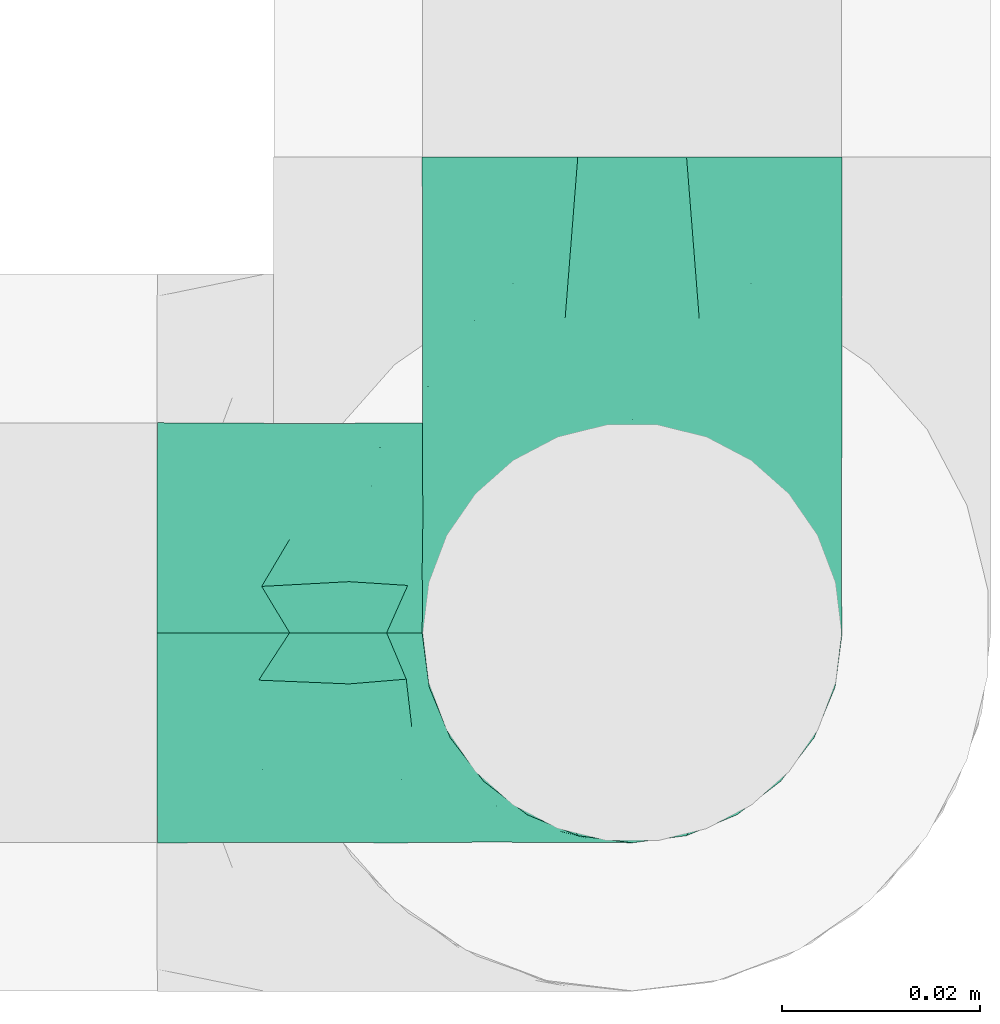
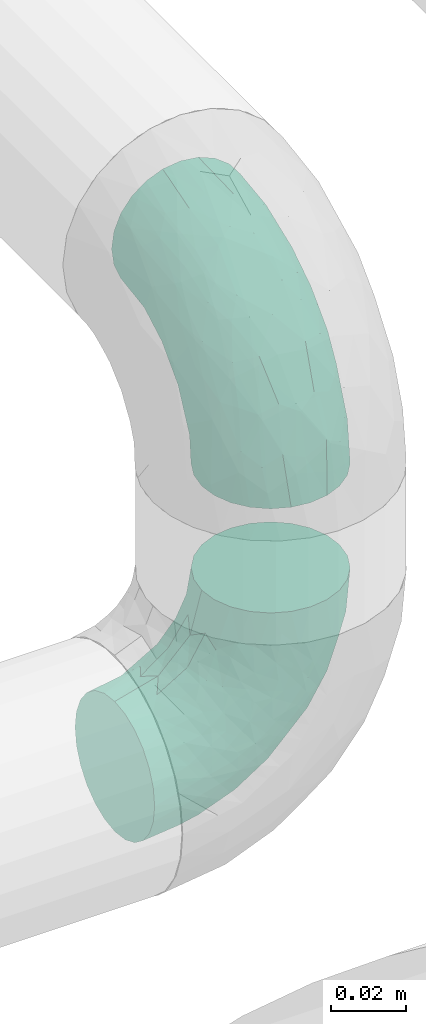
# One storey, part 35 of 39: 2 flow fittings.
"""IFC2X3 building model written with IfcOpenShell, lengths in millimetres."""

import ifcopenshell
import ifcopenshell.guid

model = None  # the IFC model being written
_history = None  # IfcOwnerHistory: only IFC2X3 demands one
_inside = {}  # id of a spatial element -> (the spatial element, [elements in it])
_under = {}  # id of a project, library or spatial element -> (it, [spatial elements below it])
_declared = {}  # id of a project -> (the project, [libraries it declares])
_typed = {}  # id of a type object -> (the type object, [elements of that type])
_made_of = {}  # id of a material, layer set ... -> (it, [elements and type objects made of it])


def new_model(schema):
    """Start an empty IFC model of exactly this schema.

    Asked for "IFC4X3", IfcOpenShell would pick the latest addendum, in which some entities
    have other attributes; the version numbers below select the first issue.
    IFC2X3 requires an IfcOwnerHistory on every rooted entity: one is made here for all.
    """
    global model, _history
    if schema == "IFC4X3":
        model = ifcopenshell.file(schema_version=(4, 3, 0, 0))
    else:
        model = ifcopenshell.file(schema=schema)
    _inside.clear()
    _under.clear()
    _declared.clear()
    _typed.clear()
    _made_of.clear()
    _history = None
    if model.schema == "IFC2X3":
        org = make("IfcOrganization", Name="unknown")
        user = make(
            "IfcPersonAndOrganization",
            ThePerson=make("IfcPerson", FamilyName="unknown"),
            TheOrganization=org,
        )
        app = make(
            "IfcApplication",
            ApplicationDeveloper=org,
            Version="unknown",
            ApplicationFullName="unknown",
            ApplicationIdentifier="unknown",
        )
        _history = make(
            "IfcOwnerHistory",
            OwningUser=user,
            OwningApplication=app,
            ChangeAction="ADDED",
            CreationDate=0,
        )
    return model


def make(cls, **values):
    """One entity of the class cls with the attributes given. An attribute that is None is left unset."""
    return model.create_entity(
        cls, **{name: value for name, value in values.items() if value is not None}
    )


def entity(cls, *values):
    """Any entity or typed value of the class cls, its attributes in the order of the schema. None: left unset."""
    e = model.create_entity(cls)
    for i, value in enumerate(values):
        if value is not None:
            e[i] = value
    return e


def rooted(cls, **values):
    """An entity with a GlobalId (a new one), such as an element, a storey or a relation."""
    return make(cls, GlobalId=ifcopenshell.guid.new(), OwnerHistory=_history, **values)


def si_unit(unit_type, name, prefix=None):
    """IfcSIUnit, for example si_unit("LENGTHUNIT", "METRE", prefix="MILLI")."""
    return make("IfcSIUnit", UnitType=unit_type, Prefix=prefix, Name=name)


def converted_unit(unit_type, name, factor, base, dimensions=None, offset=None):
    """IfcConversionBasedUnit, such as the inch: factor (a typed value) times the base unit."""
    return make(
        "IfcConversionBasedUnit"
        if offset is None
        else "IfcConversionBasedUnitWithOffset",
        ConversionOffset=offset,
        Dimensions=None
        if dimensions is None
        else entity("IfcDimensionalExponents", *dimensions),
        UnitType=unit_type,
        Name=name,
        ConversionFactor=make(
            "IfcMeasureWithUnit", ValueComponent=factor, UnitComponent=base
        ),
    )


def derived_unit(unit_type, elements):
    """IfcDerivedUnit: a product of units, each with its exponent."""
    return make(
        "IfcDerivedUnit",
        Elements=[
            make("IfcDerivedUnitElement", Unit=unit, Exponent=power)
            for unit, power in elements
        ],
        UnitType=unit_type,
    )


def assignment(units):
    """IfcUnitAssignment: the units of a project."""
    return None if units is None else make("IfcUnitAssignment", Units=units)


def point(xyz):
    """IfcCartesianPoint."""
    return None if xyz is None else make("IfcCartesianPoint", Coordinates=xyz)


def direction(xyz):
    """IfcDirection."""
    return None if xyz is None else make("IfcDirection", DirectionRatios=xyz)


def frame(location, z_axis=None, x_axis=None):
    """IfcAxis2Placement3D, a coordinate frame: its origin and axes. An axis left out is left unset."""
    return make(
        "IfcAxis2Placement3D",
        Location=point(location),
        Axis=direction(z_axis),
        RefDirection=direction(x_axis),
    )


def origin():
    """The frame at (0, 0, 0) with its axes left unset."""
    return frame((0.0, 0.0, 0.0))


def place(relative_to, where):
    """IfcLocalPlacement: puts the frame where relative to a parent placement (None: the world)."""
    return make(
        "IfcLocalPlacement", PlacementRelTo=relative_to, RelativePlacement=where
    )


def context(
    kind, dimensions, precision=None, world=None, true_north=None, identifier=None
):
    """IfcGeometricRepresentationContext, for example the 3D "Model" context."""
    return make(
        "IfcGeometricRepresentationContext",
        ContextIdentifier=identifier,
        ContextType=kind,
        CoordinateSpaceDimension=dimensions,
        Precision=precision,
        WorldCoordinateSystem=world,
        TrueNorth=true_north,
    )


def subcontext(parent, identifier, kind, view, scale=None):
    """IfcGeometricRepresentationSubContext, for example "Body" below "Model"."""
    return make(
        "IfcGeometricRepresentationSubContext",
        ContextIdentifier=identifier,
        ContextType=kind,
        ParentContext=parent,
        TargetScale=scale,
        TargetView=view,
    )


def project(units=None, contexts=None):
    """IfcProject with its units and contexts."""
    return rooted(
        "IfcProject",
        Name="project",
        RepresentationContexts=contexts,
        UnitsInContext=assignment(units),
    )


def spatial(cls, under=None, at=None, **own):
    """A site, building, storey or space (cls), placed at a placement, below another one or the project."""
    s = rooted(cls, ObjectPlacement=at, **own)
    if under is not None:
        _under.setdefault(under.id(), (under, []))[1].append(s)
    return s


def faces_of(points, faces, orient=None, outer=None):
    """IfcFace entities. A face is a list of loops; a loop is a list of indices into points, from 0.

    orient and outer hold one flag for each loop. By default every Orientation is true, the
    first loop of a face is its IfcFaceOuterBound and the others are IfcFaceBound.
    """
    made = []
    for i, loops in enumerate(faces):
        bounds = []
        for j, loop in enumerate(loops):
            is_outer = j == 0 if outer is None else outer[i][j]
            bounds.append(
                make(
                    "IfcFaceOuterBound" if is_outer else "IfcFaceBound",
                    Bound=make("IfcPolyLoop", Polygon=[points[k] for k in loop]),
                    Orientation=True if orient is None else orient[i][j],
                )
            )
        made.append(make("IfcFace", Bounds=bounds))
    return made


def faceted_brep(points, faces, orient=None, outer=None, voids=None):
    """IfcFacetedBrep: a solid bounded by flat faces; with voids (closed shells), ...WithVoids."""
    shared = [point(p) for p in points]
    hull = make("IfcClosedShell", CfsFaces=faces_of(shared, faces, orient, outer))
    if voids is None:
        return make("IfcFacetedBrep", Outer=hull)
    return make(
        "IfcFacetedBrepWithVoids",
        Outer=hull,
        Voids=[
            make(cls, CfsFaces=faces_of(shared, fs, o, b)) for cls, fs, o, b in voids
        ],
    )


def shape(context_of_items, identifier, shape_type, items):
    """IfcShapeRepresentation: the items that make up one representation, for example the "Body"."""
    return make(
        "IfcShapeRepresentation",
        ContextOfItems=context_of_items,
        RepresentationIdentifier=identifier,
        RepresentationType=shape_type,
        Items=items,
    )


def source(mapping_origin, context_of_items, identifier, shape_type, items):
    """IfcRepresentationMap: a shape defined once, which mapped items show again and again."""
    return make(
        "IfcRepresentationMap",
        MappingOrigin=mapping_origin,
        MappedRepresentation=shape(context_of_items, identifier, shape_type, items),
    )


def transform(
    local_origin,
    x_axis=None,
    y_axis=None,
    z_axis=None,
    scale=None,
    scale2=None,
    scale3=None,
    uniform=True,
):
    """IfcCartesianTransformationOperator3D, or its non-uniform kind. x_axis, y_axis, z_axis: its Axis1, 2, 3."""
    if uniform:
        return make(
            "IfcCartesianTransformationOperator3D",
            Axis1=direction(x_axis),
            Axis2=direction(y_axis),
            LocalOrigin=point(local_origin),
            Scale=scale,
            Axis3=direction(z_axis),
        )
    return make(
        "IfcCartesianTransformationOperator3DnonUniform",
        Axis1=direction(x_axis),
        Axis2=direction(y_axis),
        LocalOrigin=point(local_origin),
        Scale=scale,
        Axis3=direction(z_axis),
        Scale2=scale2,
        Scale3=scale3,
    )


def mapped(mapping_source, mapping_target):
    """IfcMappedItem: shows the shape of a source again, moved by a transform."""
    return make(
        "IfcMappedItem", MappingSource=mapping_source, MappingTarget=mapping_target
    )


def material(Name=None, Category=None):
    """IfcMaterial."""
    return make("IfcMaterial", Name=Name, Category=Category)


def made_of(thing, what):
    """Note that an element or type object is made of a material, layer set ...; save() writes the relation."""
    if what is not None:
        _made_of.setdefault(what.id(), (what, []))[1].append(thing)
    return thing


def type_object(cls, material=None, **own):
    """A type object (cls), such as IfcWallType, which elements share."""
    return made_of(rooted(cls, **own), material)


def type_shapes(of_type, sources):
    """Give a type object the sources (RepresentationMaps) that its elements show as mapped items."""
    of_type.RepresentationMaps = sources


def element(
    cls,
    number,
    at=None,
    inside=None,
    cuts=None,
    type_object=None,
    material=None,
    context=None,
    identifier="Body",
    shape_type=None,
    held_by="IfcProductDefinitionShape",
    body=None,
    shapes=None,
    **own,
):
    """One element of the class cls, such as IfcWall. Its Tag is "e" and its number.

    at: its placement. inside: the storey or other place that contains it. cuts: it is an
    opening in that element (IfcRelVoidsElement). A single representation is given by context,
    identifier, shape_type and body (its items); several are given by shapes. held_by: the class
    of the entity that holds the representations. save() writes the other relations.
    """
    e = rooted(cls, Tag="e%d" % number, ObjectPlacement=at, **own)
    if body is not None:
        shapes = [shape(context, identifier, shape_type, body)]
    if shapes is not None:
        e.Representation = make(held_by, Representations=shapes)
    if inside is not None:
        _inside.setdefault(inside.id(), (inside, []))[1].append(e)
    if cuts is not None:
        rooted(
            "IfcRelVoidsElement", RelatingBuildingElement=cuts, RelatedOpeningElement=e
        )
    if type_object is not None:
        _typed.setdefault(type_object.id(), (type_object, []))[1].append(e)
    return made_of(e, material)


def aggregate(whole, parts):
    """IfcRelAggregates: a whole, such as a stair, and the parts it consists of."""
    return rooted("IfcRelAggregates", RelatingObject=whole, RelatedObjects=parts)


def save(model, path):
    """Write the relations noted so far, then the file.

    IfcRelAggregates (storeys below a building ...), IfcRelContainedInSpatialStructure (elements
    in a storey), IfcRelDefinesByType, IfcRelAssociatesMaterial and IfcRelDeclares: one each for
    every whole, place, type object, material and project.
    """
    for whole, parts in _under.values():
        aggregate(whole, parts)
    for where, things in _inside.values():
        rooted(
            "IfcRelContainedInSpatialStructure",
            RelatedElements=things,
            RelatingStructure=where,
        )
    for kind, things in _typed.values():
        rooted("IfcRelDefinesByType", RelatedObjects=things, RelatingType=kind)
    for what, things in _made_of.values():
        rooted("IfcRelAssociatesMaterial", RelatedObjects=things, RelatingMaterial=what)
    for by, libraries in _declared.values():
        rooted("IfcRelDeclares", RelatingContext=by, RelatedDefinitions=libraries)
    model.write(path)


model = new_model("IFC2X3")

# Units and contexts
model_context = context("Model", 3, precision=0.01, world=origin(), true_north=direction((6.12303176911189e-17, 1.0)))
body_context = subcontext(model_context, "Body", "Model", "MODEL_VIEW")
ifc_project = project(units=[si_unit("LENGTHUNIT", "METRE", prefix="MILLI"), si_unit("AREAUNIT", "SQUARE_METRE"), si_unit("VOLUMEUNIT", "CUBIC_METRE"), converted_unit("PLANEANGLEUNIT", "DEGREE", entity("IfcRatioMeasure", 0.0174532925199433), si_unit("PLANEANGLEUNIT", "RADIAN"), dimensions=[0, 0, 0, 0, 0, 0, 0]), si_unit("MASSUNIT", "GRAM", prefix="KILO"), derived_unit("MASSDENSITYUNIT", [(si_unit("MASSUNIT", "GRAM", prefix="KILO"), 1), (si_unit("LENGTHUNIT", "METRE"), -3)]), derived_unit("MOMENTOFINERTIAUNIT", [(si_unit("LENGTHUNIT", "METRE"), 4)]), si_unit("TIMEUNIT", "SECOND"), si_unit("FREQUENCYUNIT", "HERTZ"), si_unit("THERMODYNAMICTEMPERATUREUNIT", "DEGREE_CELSIUS"), derived_unit("THERMALTRANSMITTANCEUNIT", [(si_unit("MASSUNIT", "GRAM", prefix="KILO"), 1), (si_unit("THERMODYNAMICTEMPERATUREUNIT", "KELVIN"), -1), (si_unit("TIMEUNIT", "SECOND"), -3)]), derived_unit("VOLUMETRICFLOWRATEUNIT", [(si_unit("LENGTHUNIT", "METRE"), 3), (si_unit("TIMEUNIT", "SECOND"), -1)]), derived_unit("MASSFLOWRATEUNIT", [(si_unit("MASSUNIT", "GRAM", prefix="KILO"), 1), (si_unit("TIMEUNIT", "SECOND"), -1)]), derived_unit("ROTATIONALFREQUENCYUNIT", [(si_unit("TIMEUNIT", "SECOND"), -1)]), si_unit("ELECTRICCURRENTUNIT", "AMPERE"), si_unit("ELECTRICVOLTAGEUNIT", "VOLT"), si_unit("POWERUNIT", "WATT"), si_unit("FORCEUNIT", "NEWTON", prefix="KILO"), si_unit("ILLUMINANCEUNIT", "LUX"), si_unit("LUMINOUSFLUXUNIT", "LUMEN"), si_unit("LUMINOUSINTENSITYUNIT", "CANDELA"), derived_unit("USERDEFINED", [(si_unit("MASSUNIT", "GRAM", prefix="KILO"), -1), (si_unit("LENGTHUNIT", "METRE"), -2), (si_unit("TIMEUNIT", "SECOND"), 3), (si_unit("LUMINOUSFLUXUNIT", "LUMEN"), 1)]), derived_unit("LINEARVELOCITYUNIT", [(si_unit("LENGTHUNIT", "METRE"), 1), (si_unit("TIMEUNIT", "SECOND"), -1)]), si_unit("PRESSUREUNIT", "PASCAL"), derived_unit("USERDEFINED", [(si_unit("LENGTHUNIT", "METRE"), -2), (si_unit("MASSUNIT", "GRAM", prefix="KILO"), 1), (si_unit("TIMEUNIT", "SECOND"), -2)]), derived_unit("LINEARFORCEUNIT", [(si_unit("MASSUNIT", "GRAM", prefix="KILO"), 1), (si_unit("LENGTHUNIT", "METRE"), 1), (si_unit("TIMEUNIT", "SECOND"), -2), (si_unit("LENGTHUNIT", "METRE"), -1)]), derived_unit("PLANARFORCEUNIT", [(si_unit("MASSUNIT", "GRAM", prefix="KILO"), 1), (si_unit("LENGTHUNIT", "METRE"), 1), (si_unit("TIMEUNIT", "SECOND"), -2), (si_unit("LENGTHUNIT", "METRE"), -2)])], contexts=[model_context])

# Site, building, storey
site_placement = place(None, origin())
site = spatial("IfcSite", under=ifc_project, at=site_placement, CompositionType="ELEMENT")
building_placement = place(site_placement, origin())
building = spatial("IfcBuilding", under=site, at=building_placement, CompositionType="ELEMENT")
storey_placement = place(building_placement, frame((0.0, 0.0, 24000.0)))
storey = spatial("IfcBuildingStorey", under=building, at=storey_placement, Name="07", CompositionType="ELEMENT", Elevation=24000.0)

# Flow fittings
ifc_material = material()
pipe_fitting_type_1 = type_object("IfcPipeFittingType", Name="ADSK_1", PredefinedType="NOTDEFINED", material=ifc_material)
shared_shape_1 = source(origin(), body_context, "Body", "Brep", [
    faceted_brep([(-48.0, 10.6, -18.36), (-48.0, 5.49, -20.48), (-48.0, 0.0, -21.2), (-48.0, -5.49, -20.48), (-48.0, -10.6, -18.36), (-48.0, -14.99, -14.99), (-48.0, -18.36, -10.6), (-48.0, -20.48, -5.49), (-48.0, -21.2, 0.0), (-48.0, -20.48, 5.49), (-48.0, -18.36, 10.6), (-48.0, -14.99, 14.99), (-48.0, -10.6, 18.36), (-48.0, -5.49, 20.48), (-48.0, 0.0, 21.2), (-48.0, 5.49, 20.48), (-48.0, 10.6, 18.36), (-48.0, 14.99, 14.99), (-48.0, 18.36, 10.6), (-48.0, 20.48, 5.49), (-48.0, 21.2, 0.0), (-48.0, 20.48, -5.49), (-48.0, 18.36, -10.6), (-48.0, 14.99, -14.99), (0.0, 48.0, -21.2), (-5.48, 48.0, -20.48), (-10.6, 48.0, -18.36), (-14.99, 48.0, -14.99), (-18.36, 48.0, -10.6), (-20.47, 48.0, -5.49), (-21.2, 48.0, 0.0), (-20.47, 48.0, 5.49), (-18.36, 48.0, 10.6), (-14.99, 48.0, 14.99), (-10.6, 48.0, 18.36), (-5.48, 48.0, 20.48), (0.0, 48.0, 21.2), (5.49, 48.0, 20.48), (10.6, 48.0, 18.36), (14.99, 48.0, 14.99), (18.36, 47.99, 10.6), (20.48, 47.99, 5.49), (21.2, 47.99, 0.0), (20.48, 47.99, -5.49), (18.36, 47.99, -10.6), (14.99, 48.0, -14.99), (10.6, 48.0, -18.36), (5.49, 48.0, -20.48), (-35.25, -16.22, 12.01), (-34.76, -18.57, 0.0), (-20.87, -12.37, 10.9), (-31.48, -11.78, 15.9), (-37.0, -2.58, 20.86), (-33.88, 3.62, 21.15), (-31.8, -18.14, 6.76), (-5.78, 5.78, 17.67), (-19.42, -4.11, 17.86), (-9.59, -3.39, 13.73), (-35.44, -7.73, 19.13), (11.79, 31.48, 15.9), (-5.93, -5.46, 6.95), (-18.45, -13.78, 5.46), (-10.29, -8.43, 0.0), (-24.6, 0.55, 20.62), (-37.28, 17.94, 13.81), (-33.37, 22.85, 9.59), (-41.46, 20.06, 8.75), (-29.51, 20.45, 15.16), (-15.04, 10.79, 21.13), (-7.08, 16.98, 20.93), (-8.38, 23.51, 21.15), (-40.86, 13.03, 17.26), (-8.05, 41.26, 19.83), (-3.21, 35.97, 21.14), (8.53, 19.65, 14.74), (4.11, 19.42, 17.86), (-37.72, 22.66, 4.78), (-37.06, 8.58, 19.98), (-12.99, 5.43, 19.97), (-3.78, 13.92, 19.7), (3.02, 8.69, 13.43), (-2.27, -0.05, 10.65), (6.22, 6.99, 7.1), (-22.25, 34.6, 9.45), (18.14, 31.8, 6.76), (16.22, 35.25, 12.01), (12.37, 20.87, 10.9), (7.74, 35.44, 19.13), (-21.52, -15.93, 0.0), (2.58, 37.0, 20.86), (18.57, 34.75, 0.0), (13.78, 18.45, 5.46), (15.93, 21.51, 0.0), (-20.03, -8.54, 14.9), (-28.6, 28.6, 5.16), (-24.79, 34.6, 0.0), (-34.6, 24.79, 0.0), (-22.81, 37.41, 4.68), (-23.35, 26.33, 14.79), (-13.68, 37.05, 17.49), (-17.72, 38.12, 13.73), (-26.25, 27.3, 11.24), (-9.71, 32.34, 20.14), (-17.26, 25.6, 18.71), (-26.33, 9.99, 20.77), (-24.06, 6.05, 21.2), (-25.02, 15.46, 19.56), (-24.3, 20.72, 17.57), (-31.95, 15.23, 17.8), (-13.52, 24.7, 20.21), (-0.54, 24.6, 20.62), (-11.41, -7.48, 10.43), (-17.6, 17.6, 20.6), (0.93, -0.93, 0.0), (8.43, 10.29, 0.0), (-11.41, -7.48, -10.43), (-20.1, -8.84, -14.66), (-9.59, -3.39, -13.73), (7.74, 35.44, -19.13), (4.11, 19.42, -17.86), (-0.54, 24.6, -20.62), (-38.12, 17.72, -13.73), (-37.05, 13.68, -17.49), (-32.34, 9.71, -20.14), (-41.26, 8.05, -19.83), (-37.41, 22.81, -4.68), (-23.51, 8.39, -21.15), (-35.97, 3.21, -21.14), (-28.6, 28.6, -5.16), (-31.8, -18.14, -6.76), (-18.45, -13.78, -5.46), (-25.6, 17.26, -18.71), (-19.42, -4.11, -17.86), (-17.94, 37.28, -13.81), (-22.85, 33.38, -9.59), (-20.06, 41.46, -8.75), (-31.48, -11.78, -15.9), (-35.25, -16.22, -12.01), (8.53, 19.65, -14.74), (11.79, 31.48, -15.9), (-9.99, 26.33, -20.77), (-6.05, 24.06, -21.2), (-10.78, 15.04, -21.13), (-37.0, -2.58, -20.86), (-16.98, 7.08, -20.93), (-5.43, 12.99, -19.97), (-13.92, 3.78, -19.7), (-20.87, -12.37, -10.9), (-26.33, 23.36, -14.79), (-22.65, 37.72, -4.78), (13.78, 18.45, -5.46), (18.14, 31.8, -6.76), (-15.46, 25.02, -19.56), (-20.72, 24.3, -17.57), (16.22, 35.25, -12.01), (-13.03, 40.86, -17.26), (-8.58, 37.06, -19.98), (2.58, 37.0, -20.86), (-3.61, 33.88, -21.15), (-34.6, 22.25, -9.45), (6.22, 6.99, -7.1), (-20.45, 29.51, -15.16), (-35.44, -7.73, -19.13), (12.37, 20.87, -10.9), (-27.29, 26.25, -11.24), (-15.23, 31.95, -17.8), (-24.7, 13.53, -20.21), (-24.6, 0.55, -20.62), (-5.78, 5.78, -17.67), (-17.6, 17.6, -20.6), (3.02, 8.69, -13.43), (-5.93, -5.46, -6.95), (-2.27, -0.05, -10.65)], [[[0, 1, 2, 3, 4, 5, 6, 7, 8, 9, 10, 11, 12, 13, 14, 15, 16, 17, 18, 19, 20, 21, 22, 23]], [[24, 25, 26, 27, 28, 29, 30, 31, 32, 33, 34, 35, 36, 37, 38, 39, 40, 41, 42, 43, 44, 45, 46, 47]], [[10, 48, 11]], [[9, 8, 49]], [[48, 50, 51]], [[14, 52, 53]], [[10, 54, 48]], [[9, 54, 10]], [[55, 56, 57]], [[51, 12, 11]], [[51, 58, 12]], [[59, 39, 38]], [[60, 61, 62]], [[58, 56, 63]], [[64, 65, 66]], [[67, 65, 64]], [[68, 69, 70]], [[16, 71, 17]], [[13, 52, 14]], [[35, 72, 73]], [[14, 53, 15]], [[17, 64, 18]], [[74, 59, 75]], [[20, 19, 76]], [[66, 19, 18]], [[77, 15, 53]], [[15, 77, 16]], [[69, 78, 79]], [[80, 81, 82]], [[32, 31, 83]], [[84, 85, 86]], [[59, 87, 75]], [[61, 54, 88]], [[36, 89, 37]], [[84, 41, 40]], [[36, 35, 73]], [[90, 41, 84]], [[40, 39, 85]], [[12, 58, 13]], [[85, 84, 40]], [[91, 84, 86]], [[84, 92, 90]], [[87, 38, 37]], [[93, 56, 51]], [[65, 94, 76]], [[94, 95, 96]], [[84, 91, 92]], [[95, 97, 30]], [[98, 99, 100]], [[76, 94, 96]], [[101, 98, 83]], [[100, 99, 33]], [[102, 70, 73]], [[103, 102, 99]], [[94, 97, 95]], [[72, 99, 102]], [[72, 35, 34]], [[34, 33, 99]], [[9, 49, 54]], [[87, 59, 38]], [[104, 105, 68]], [[106, 103, 107]], [[106, 77, 104]], [[71, 64, 17]], [[108, 107, 67]], [[33, 32, 100]], [[102, 103, 109]], [[102, 109, 70]], [[89, 73, 110]], [[50, 48, 54]], [[51, 11, 48]], [[56, 58, 51]], [[88, 54, 49]], [[52, 58, 63]], [[50, 111, 93]], [[56, 55, 78]], [[39, 59, 85]], [[86, 85, 59]], [[89, 87, 37]], [[42, 41, 90]], [[110, 79, 75]], [[110, 75, 87]], [[75, 55, 80]], [[104, 77, 53]], [[71, 77, 108]], [[32, 83, 100]], [[98, 100, 83]], [[99, 98, 103]], [[106, 107, 108]], [[68, 70, 112]], [[110, 73, 70]], [[68, 112, 104]], [[68, 63, 78]], [[57, 93, 111]], [[80, 55, 57]], [[61, 50, 54]], [[80, 82, 86]], [[81, 57, 111]], [[74, 86, 59]], [[60, 113, 82]], [[82, 114, 91]], [[101, 94, 65]], [[97, 94, 83]], [[73, 89, 36]], [[87, 89, 110]], [[58, 52, 13]], [[53, 52, 63]], [[104, 53, 105]], [[106, 104, 112]], [[20, 76, 96]], [[76, 19, 66]], [[103, 106, 112]], [[77, 106, 108]], [[103, 98, 107]], [[67, 107, 98]], [[67, 98, 101]], [[108, 67, 64]], [[53, 63, 105]], [[63, 68, 105]], [[83, 31, 97]], [[30, 97, 31]], [[62, 113, 60]], [[111, 61, 60]], [[61, 88, 62]], [[86, 82, 91]], [[56, 78, 63]], [[114, 82, 113]], [[114, 92, 91]], [[79, 78, 55]], [[75, 79, 55]], [[69, 79, 110]], [[70, 69, 110]], [[78, 69, 68]], [[77, 71, 16]], [[64, 71, 108]], [[64, 66, 18]], [[76, 66, 65]], [[99, 72, 34]], [[73, 72, 102]], [[94, 101, 83]], [[67, 101, 65]], [[75, 80, 74]], [[80, 86, 74]], [[103, 112, 109]], [[70, 109, 112]], [[50, 93, 51]], [[57, 56, 93]], [[61, 111, 50]], [[81, 111, 60]], [[82, 81, 60]], [[80, 57, 81]], [[115, 116, 117]], [[118, 119, 120]], [[121, 122, 23]], [[123, 124, 122]], [[96, 125, 20]], [[123, 126, 127]], [[128, 96, 95]], [[129, 130, 88]], [[123, 122, 131]], [[116, 132, 117]], [[133, 134, 135]], [[0, 124, 1]], [[5, 136, 137]], [[138, 119, 139]], [[129, 88, 49]], [[140, 141, 142]], [[6, 5, 137]], [[46, 118, 47]], [[143, 3, 2]], [[144, 145, 146]], [[6, 129, 7]], [[129, 137, 147]], [[127, 2, 1]], [[148, 122, 121]], [[128, 125, 96]], [[134, 128, 149]], [[95, 149, 128]], [[150, 151, 92]], [[30, 29, 149]], [[152, 131, 153]], [[27, 133, 28]], [[154, 45, 44]], [[136, 5, 4]], [[27, 26, 155]], [[156, 26, 25]], [[24, 157, 158]], [[24, 47, 157]], [[22, 21, 159]], [[160, 150, 114]], [[134, 133, 161]], [[142, 144, 126]], [[46, 139, 118]], [[162, 136, 4]], [[156, 25, 158]], [[1, 124, 127]], [[115, 147, 116]], [[45, 154, 139]], [[139, 46, 45]], [[154, 163, 139]], [[162, 4, 3]], [[42, 90, 43]], [[130, 129, 147]], [[49, 7, 129]], [[43, 151, 44]], [[0, 23, 122]], [[24, 158, 25]], [[136, 162, 132]], [[135, 29, 28]], [[43, 90, 151]], [[164, 148, 159]], [[152, 156, 140]], [[155, 133, 27]], [[165, 153, 161]], [[23, 22, 121]], [[123, 131, 166]], [[123, 166, 126]], [[143, 127, 167]], [[147, 137, 136]], [[8, 7, 49]], [[129, 6, 137]], [[143, 162, 3]], [[167, 146, 132]], [[167, 132, 162]], [[132, 168, 117]], [[44, 151, 154]], [[92, 151, 90]], [[163, 154, 151]], [[119, 118, 139]], [[157, 118, 120]], [[138, 139, 163]], [[119, 168, 145]], [[140, 156, 158]], [[155, 156, 165]], [[22, 159, 121]], [[148, 121, 159]], [[122, 148, 131]], [[152, 153, 165]], [[142, 126, 169]], [[167, 127, 126]], [[142, 169, 140]], [[142, 120, 145]], [[168, 170, 117]], [[160, 171, 172]], [[115, 172, 171]], [[171, 62, 130]], [[119, 170, 168]], [[170, 163, 160]], [[150, 163, 151]], [[113, 171, 160]], [[164, 128, 134]], [[125, 128, 159]], [[127, 143, 2]], [[162, 143, 167]], [[118, 157, 47]], [[158, 157, 120]], [[140, 158, 141]], [[152, 140, 169]], [[30, 149, 95]], [[149, 29, 135]], [[131, 152, 169]], [[156, 152, 165]], [[131, 148, 153]], [[161, 153, 148]], [[161, 148, 164]], [[165, 161, 133]], [[158, 120, 141]], [[120, 142, 141]], [[159, 21, 125]], [[20, 125, 21]], [[115, 130, 147]], [[114, 113, 160]], [[62, 171, 113]], [[62, 88, 130]], [[160, 163, 150]], [[150, 92, 114]], [[119, 145, 120]], [[146, 145, 168]], [[132, 146, 168]], [[144, 146, 167]], [[126, 144, 167]], [[145, 144, 142]], [[156, 155, 26]], [[133, 155, 165]], [[133, 135, 28]], [[149, 135, 134]], [[122, 124, 0]], [[127, 124, 123]], [[128, 164, 159]], [[161, 164, 134]], [[163, 170, 138]], [[170, 119, 138]], [[131, 169, 166]], [[126, 166, 169]], [[147, 136, 116]], [[132, 116, 136]], [[172, 115, 117]], [[130, 115, 171]], [[117, 170, 172]], [[160, 172, 170]]]),
])
type_shapes(pipe_fitting_type_1, [shared_shape_1])
flow_fitting_1_placement = place(storey_placement, frame((68520.08, 1601.17, 3029.9), z_axis=(1.0, 0.0, 0.0), x_axis=(0.0, -0.999999996965674, -7.79015519760358e-05)))
element("IfcFlowFitting", 1, at=flow_fitting_1_placement, inside=storey, type_object=pipe_fitting_type_1, material=ifc_material, Name="ADSK_1", ObjectType="ADSK_1", context=body_context, shape_type="MappedRepresentation", body=[
    mapped(shared_shape_1, transform((0.0, 0.0, 0.0), scale=1.0)),
])
pipe_fitting_type_2 = type_object("IfcPipeFittingType", Name="ADSK_1", PredefinedType="NOTDEFINED", material=ifc_material)
shared_shape_2 = source(origin(), body_context, "Body", "Brep", [
    faceted_brep([(-47.9, 10.6, -18.36), (-47.9, 5.49, -20.48), (-47.9, 0.0, -21.2), (-47.9, -5.49, -20.48), (-47.9, -10.6, -18.36), (-47.9, -14.99, -14.99), (-47.9, -18.36, -10.6), (-47.9, -20.48, -5.49), (-47.9, -21.2, 0.0), (-47.9, -20.48, 5.49), (-47.9, -18.36, 10.6), (-47.9, -14.99, 14.99), (-47.9, -10.6, 18.36), (-47.9, -5.49, 20.48), (-47.9, 0.0, 21.2), (-47.9, 5.49, 20.48), (-47.9, 10.6, 18.36), (-47.9, 14.99, 14.99), (-47.9, 18.36, 10.6), (-47.9, 20.48, 5.49), (-47.9, 21.2, 0.0), (-47.9, 20.48, -5.49), (-47.9, 18.36, -10.6), (-47.9, 14.99, -14.99), (-5.39, 47.91, -20.48), (-10.5, 47.93, -18.36), (-14.89, 47.93, -14.99), (-18.26, 47.94, -10.6), (-20.38, 47.94, -5.49), (-21.1, 47.95, 0.0), (-20.38, 47.94, 5.49), (-18.26, 47.94, 10.6), (-14.89, 47.93, 14.99), (-10.5, 47.93, 18.36), (-5.39, 47.91, 20.48), (0.1, 47.9, 21.2), (5.58, 47.89, 20.48), (10.7, 47.88, 18.36), (15.09, 47.87, 14.99), (18.46, 47.87, 10.6), (20.57, 47.86, 5.49), (21.3, 47.86, 0.0), (20.57, 47.86, -5.49), (18.46, 47.87, -10.6), (15.09, 47.87, -14.99), (10.7, 47.88, -18.36), (5.58, 47.89, -20.48), (0.1, 47.9, -21.2), (-35.16, -16.22, 12.01), (-34.68, -18.57, 0.0), (-20.76, -12.36, 10.9), (-31.39, -11.78, 15.9), (-36.92, -2.58, 20.86), (-33.8, 3.61, 21.15), (-31.71, -18.14, 6.76), (-5.73, 5.74, 17.68), (-19.35, -4.12, 17.86), (-9.54, -3.41, 13.74), (-35.35, -7.73, 19.13), (11.85, 31.36, 15.9), (-5.82, -5.44, 6.97), (-18.34, -13.78, 5.45), (-10.24, -8.46, 0.0), (-24.53, 0.54, 20.62), (-37.19, 17.94, 13.8), (-33.3, 22.84, 9.58), (-41.38, 20.06, 8.75), (-29.44, 20.43, 15.16), (-15.0, 10.76, 21.13), (-7.03, 16.91, 20.93), (-8.33, 23.47, 21.15), (-40.78, 13.03, 17.26), (-7.97, 41.2, 19.83), (-3.14, 35.89, 21.14), (8.57, 19.54, 14.74), (4.16, 19.35, 17.86), (-37.64, 22.65, 4.78), (-36.97, 8.58, 19.98), (-12.93, 5.42, 19.97), (-3.72, 13.89, 19.7), (3.06, 8.65, 13.45), (-2.17, -0.03, 10.67), (6.23, 6.93, 7.17), (-22.18, 34.56, 9.45), (18.2, 31.67, 6.76), (16.29, 35.12, 12.01), (12.41, 20.74, 10.9), (7.8, 35.33, 19.13), (-21.45, -15.95, 0.0), (2.65, 36.92, 20.86), (18.64, 34.64, 0.0), (13.6, 17.86, 5.42), (15.99, 21.42, 0.0), (-19.95, -8.54, 14.91), (-28.52, 28.58, 5.16), (-24.71, 34.57, 0.0), (-34.52, 24.78, 0.0), (-22.73, 37.39, 4.68), (-23.3, 26.29, 14.79), (-13.61, 36.99, 17.49), (-17.64, 38.07, 13.73), (-26.18, 27.27, 11.24), (-9.64, 32.29, 20.13), (-17.19, 25.56, 18.71), (-26.26, 9.98, 20.77), (-24.0, 6.05, 21.2), (-24.96, 15.44, 19.56), (-24.23, 20.7, 17.57), (-31.89, 15.22, 17.8), (-13.46, 24.66, 20.21), (-17.54, 17.57, 20.6), (-0.49, 24.53, 20.62), (-11.31, -7.47, 10.44), (0.98, -0.98, 0.0), (8.48, 10.22, 0.0), (-11.31, -7.47, -10.44), (-20.03, -8.85, -14.66), (-9.54, -3.41, -13.74), (7.8, 35.33, -19.13), (4.16, 19.35, -17.86), (-0.49, 24.53, -20.62), (-38.03, 17.72, -13.73), (-36.96, 13.68, -17.49), (-32.27, 9.71, -20.13), (-41.18, 8.05, -19.83), (-37.34, 22.8, -4.68), (-23.45, 8.38, -21.15), (-35.88, 3.21, -21.14), (-28.52, 28.58, -5.16), (-31.71, -18.14, -6.76), (-18.34, -13.78, -5.45), (-25.53, 17.24, -18.71), (-19.35, -4.12, -17.86), (-17.87, 37.23, -13.8), (-22.78, 33.35, -9.58), (-19.98, 41.42, -8.75), (-31.39, -11.78, -15.9), (-35.16, -16.22, -12.01), (8.57, 19.54, -14.74), (11.85, 31.36, -15.9), (-9.93, 26.28, -20.77), (-6.0, 24.01, -21.2), (-10.73, 15.02, -21.13), (-36.92, -2.58, -20.86), (-16.9, 7.06, -20.93), (-5.4, 12.94, -19.97), (-13.88, 3.75, -19.7), (-20.76, -12.36, -10.9), (-26.25, 23.35, -14.79), (-22.58, 37.69, -4.78), (13.6, 17.86, -5.42), (18.2, 31.67, -6.76), (-15.39, 24.99, -19.56), (-20.65, 24.27, -17.57), (16.29, 35.12, -12.01), (-12.95, 40.81, -17.26), (-8.51, 36.99, -19.98), (2.65, 36.92, -20.86), (-3.55, 33.81, -21.15), (-34.51, 22.25, -9.45), (6.23, 6.93, -7.17), (-20.37, 29.48, -15.16), (-35.35, -7.73, -19.13), (12.41, 20.74, -10.9), (-27.22, 26.24, -11.24), (-15.16, 31.92, -17.8), (-24.64, 13.51, -20.21), (-17.54, 17.57, -20.6), (-24.53, 0.54, -20.62), (-5.73, 5.74, -17.68), (3.06, 8.65, -13.45), (-5.82, -5.44, -6.97), (-2.17, -0.03, -10.67)], [[[0, 1, 2, 3, 4, 5, 6, 7, 8, 9, 10, 11, 12, 13, 14, 15, 16, 17, 18, 19, 20, 21, 22, 23]], [[24, 25, 26, 27, 28, 29, 30, 31, 32, 33, 34, 35, 36, 37, 38, 39, 40, 41, 42, 43, 44, 45, 46, 47]], [[10, 48, 11]], [[9, 8, 49]], [[48, 50, 51]], [[14, 52, 53]], [[10, 54, 48]], [[9, 54, 10]], [[55, 56, 57]], [[51, 12, 11]], [[51, 58, 12]], [[59, 38, 37]], [[60, 61, 62]], [[58, 56, 63]], [[64, 65, 66]], [[67, 65, 64]], [[68, 69, 70]], [[16, 71, 17]], [[13, 52, 14]], [[34, 72, 73]], [[14, 53, 15]], [[17, 64, 18]], [[74, 59, 75]], [[20, 19, 76]], [[66, 19, 18]], [[77, 15, 53]], [[15, 77, 16]], [[69, 78, 79]], [[80, 81, 82]], [[31, 30, 83]], [[84, 85, 86]], [[59, 87, 75]], [[61, 54, 88]], [[35, 89, 36]], [[84, 40, 39]], [[35, 34, 73]], [[90, 40, 84]], [[39, 38, 85]], [[12, 58, 13]], [[85, 84, 39]], [[91, 84, 86]], [[84, 92, 90]], [[87, 37, 36]], [[93, 56, 51]], [[65, 94, 76]], [[94, 95, 96]], [[91, 86, 82]], [[95, 97, 29]], [[98, 99, 100]], [[76, 94, 96]], [[101, 98, 83]], [[100, 99, 32]], [[102, 70, 73]], [[103, 102, 99]], [[94, 97, 95]], [[72, 99, 102]], [[72, 34, 33]], [[33, 32, 99]], [[9, 49, 54]], [[87, 59, 37]], [[104, 105, 68]], [[106, 103, 107]], [[106, 77, 104]], [[71, 64, 17]], [[108, 107, 67]], [[32, 31, 100]], [[109, 103, 110]], [[102, 109, 70]], [[89, 73, 111]], [[50, 48, 54]], [[51, 11, 48]], [[56, 58, 51]], [[88, 54, 49]], [[52, 58, 63]], [[50, 112, 93]], [[56, 55, 78]], [[38, 59, 85]], [[86, 85, 59]], [[89, 87, 36]], [[41, 40, 90]], [[111, 79, 75]], [[111, 75, 87]], [[75, 55, 80]], [[104, 77, 53]], [[71, 77, 108]], [[31, 83, 100]], [[98, 100, 83]], [[57, 93, 112]], [[80, 55, 57]], [[61, 50, 54]], [[80, 82, 86]], [[81, 57, 112]], [[74, 86, 59]], [[60, 113, 82]], [[82, 114, 91]], [[99, 98, 103]], [[106, 107, 108]], [[68, 70, 110]], [[111, 73, 70]], [[68, 110, 104]], [[68, 63, 78]], [[101, 94, 65]], [[97, 94, 83]], [[73, 89, 35]], [[87, 89, 111]], [[58, 52, 13]], [[53, 52, 63]], [[104, 53, 105]], [[106, 104, 110]], [[20, 76, 96]], [[76, 19, 66]], [[103, 106, 110]], [[77, 106, 108]], [[103, 98, 107]], [[67, 107, 98]], [[67, 98, 101]], [[108, 67, 64]], [[83, 30, 97]], [[29, 97, 30]], [[53, 63, 105]], [[63, 68, 105]], [[56, 78, 63]], [[84, 91, 92]], [[114, 82, 113]], [[114, 92, 91]], [[79, 78, 55]], [[75, 79, 55]], [[69, 79, 111]], [[70, 69, 111]], [[78, 69, 68]], [[62, 113, 60]], [[112, 61, 60]], [[61, 88, 62]], [[77, 71, 16]], [[64, 71, 108]], [[64, 66, 18]], [[76, 66, 65]], [[99, 72, 33]], [[73, 72, 102]], [[94, 101, 83]], [[67, 101, 65]], [[75, 80, 74]], [[80, 86, 74]], [[50, 93, 51]], [[57, 56, 93]], [[61, 112, 50]], [[81, 112, 60]], [[82, 81, 60]], [[80, 57, 81]], [[70, 109, 110]], [[102, 103, 109]], [[115, 116, 117]], [[118, 119, 120]], [[121, 122, 23]], [[123, 124, 122]], [[96, 125, 20]], [[123, 126, 127]], [[128, 96, 95]], [[129, 130, 88]], [[123, 122, 131]], [[116, 132, 117]], [[133, 134, 135]], [[0, 124, 1]], [[5, 136, 137]], [[138, 119, 139]], [[129, 88, 49]], [[140, 141, 142]], [[6, 5, 137]], [[45, 118, 46]], [[143, 3, 2]], [[144, 145, 146]], [[6, 129, 7]], [[129, 137, 147]], [[127, 2, 1]], [[148, 122, 121]], [[128, 125, 96]], [[134, 128, 149]], [[95, 149, 128]], [[150, 151, 92]], [[29, 28, 149]], [[152, 131, 153]], [[26, 133, 27]], [[154, 44, 43]], [[136, 5, 4]], [[26, 25, 155]], [[156, 25, 24]], [[47, 157, 158]], [[47, 46, 157]], [[22, 21, 159]], [[160, 150, 114]], [[134, 133, 161]], [[142, 144, 126]], [[45, 139, 118]], [[162, 136, 4]], [[156, 24, 158]], [[1, 124, 127]], [[115, 147, 116]], [[44, 154, 139]], [[139, 45, 44]], [[154, 163, 139]], [[162, 4, 3]], [[41, 90, 42]], [[130, 129, 147]], [[49, 7, 129]], [[42, 151, 43]], [[0, 23, 122]], [[47, 158, 24]], [[136, 162, 132]], [[135, 28, 27]], [[42, 90, 151]], [[164, 148, 159]], [[152, 156, 140]], [[155, 133, 26]], [[165, 153, 161]], [[23, 22, 121]], [[166, 131, 167]], [[123, 166, 126]], [[143, 127, 168]], [[147, 137, 136]], [[8, 7, 49]], [[129, 6, 137]], [[143, 162, 3]], [[168, 146, 132]], [[168, 132, 162]], [[132, 169, 117]], [[43, 151, 154]], [[92, 151, 90]], [[163, 154, 151]], [[119, 118, 139]], [[157, 118, 120]], [[138, 139, 163]], [[119, 169, 145]], [[140, 156, 158]], [[155, 156, 165]], [[22, 159, 121]], [[148, 121, 159]], [[169, 170, 117]], [[160, 171, 172]], [[115, 172, 171]], [[171, 62, 130]], [[119, 170, 169]], [[170, 163, 160]], [[150, 160, 163]], [[113, 171, 160]], [[122, 148, 131]], [[152, 153, 165]], [[142, 126, 167]], [[168, 127, 126]], [[142, 167, 140]], [[142, 120, 145]], [[164, 128, 134]], [[125, 128, 159]], [[127, 143, 2]], [[162, 143, 168]], [[118, 157, 46]], [[158, 157, 120]], [[140, 158, 141]], [[152, 140, 167]], [[29, 149, 95]], [[149, 28, 135]], [[131, 152, 167]], [[156, 152, 165]], [[131, 148, 153]], [[161, 153, 148]], [[161, 148, 164]], [[165, 161, 133]], [[159, 21, 125]], [[20, 125, 21]], [[158, 120, 141]], [[120, 142, 141]], [[151, 150, 163]], [[114, 113, 160]], [[150, 92, 114]], [[119, 145, 120]], [[146, 145, 169]], [[132, 146, 169]], [[144, 146, 168]], [[126, 144, 168]], [[145, 144, 142]], [[115, 130, 147]], [[156, 155, 25]], [[62, 171, 113]], [[62, 88, 130]], [[133, 155, 165]], [[133, 135, 27]], [[149, 135, 134]], [[122, 124, 0]], [[127, 124, 123]], [[128, 164, 159]], [[161, 164, 134]], [[163, 170, 138]], [[170, 119, 138]], [[147, 136, 116]], [[132, 116, 136]], [[172, 115, 117]], [[130, 115, 171]], [[117, 170, 172]], [[160, 172, 170]], [[126, 166, 167]], [[123, 131, 166]]]),
])
type_shapes(pipe_fitting_type_2, [shared_shape_2])
flow_fitting_2_placement = place(storey_placement, frame((68520.08, 1601.17, 2900.14), z_axis=(0.0, 1.0, 0.0), x_axis=(0.0, 0.0, -1.0)))
element("IfcFlowFitting", 2, at=flow_fitting_2_placement, inside=storey, type_object=pipe_fitting_type_2, material=ifc_material, Name="ADSK_1", ObjectType="ADSK_1", context=body_context, shape_type="MappedRepresentation", body=[
    mapped(shared_shape_2, transform((0.0, 0.0, 0.0), scale=1.0)),
])

save(model, "model.ifc")
